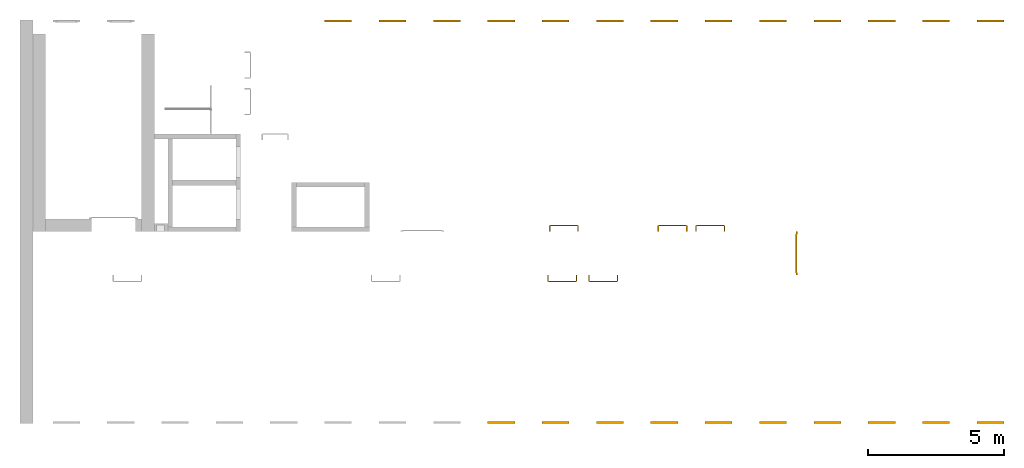
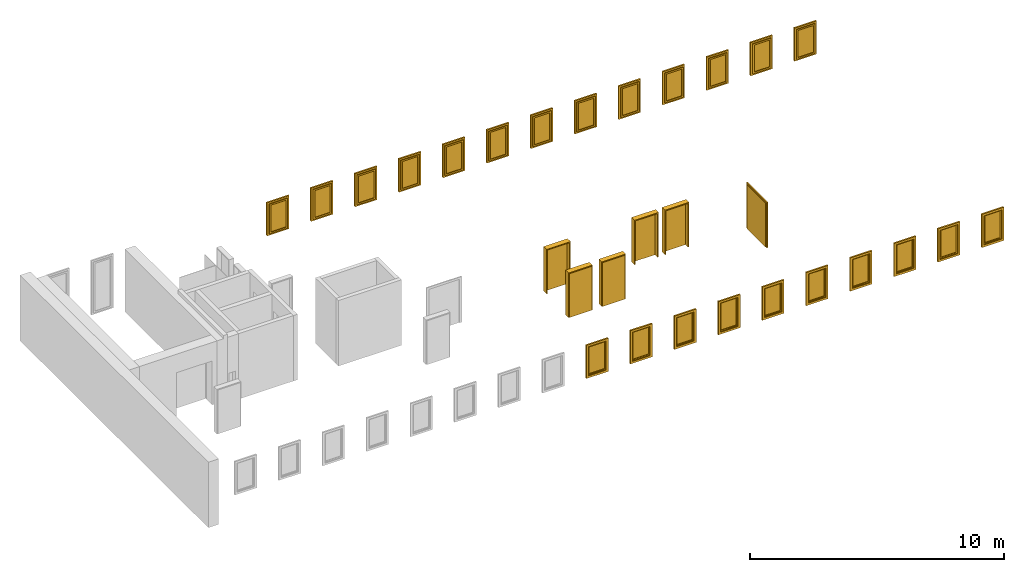
# One storey, part 3 of 3: 23 windows, 6 doors.
"""IFC4 building model written with IfcOpenShell, lengths in metres."""

from ifc_helpers import new_model, entity, si_unit, converted_unit, derived_unit, direction, frame, origin_with_axes, place, context, subcontext, project, spatial, polygons, source, transform, mapped, type_object, element, save


model = new_model("IFC4")

# Units and contexts
model_context = context("Model", 3, precision=1e-05, world=origin_with_axes(), true_north=direction((0.0, 1.0)))
body_context = subcontext(model_context, "Body", "Model", "MODEL_VIEW")
ifc_project = project(units=[si_unit("LENGTHUNIT", "METRE"), si_unit("AREAUNIT", "SQUARE_METRE"), si_unit("VOLUMEUNIT", "CUBIC_METRE"), converted_unit("PLANEANGLEUNIT", "DEGREE", entity("IfcPlaneAngleMeasure", 0.0174532925199433), si_unit("PLANEANGLEUNIT", "RADIAN"), dimensions=[0, 0, 0, 0, 0, 0, 0]), converted_unit("TIMEUNIT", "Year", entity("IfcTimeMeasure", 31557600.0), si_unit("TIMEUNIT", "SECOND"), dimensions=[0, 0, 1, 0, 0, 0, 0]), si_unit("MASSUNIT", "GRAM", prefix="KILO"), si_unit("THERMODYNAMICTEMPERATUREUNIT", "DEGREE_CELSIUS"), si_unit("LUMINOUSINTENSITYUNIT", "LUMEN"), si_unit("ENERGYUNIT", "JOULE", prefix="MEGA"), derived_unit("THERMALCONDUCTANCEUNIT", [(si_unit("POWERUNIT", "WATT"), 1), (si_unit("LENGTHUNIT", "METRE"), -1), (si_unit("THERMODYNAMICTEMPERATUREUNIT", "KELVIN"), -1)]), derived_unit("SPECIFICHEATCAPACITYUNIT", [(si_unit("ENERGYUNIT", "JOULE"), 1), (si_unit("MASSUNIT", "GRAM", prefix="KILO"), -1), (si_unit("THERMODYNAMICTEMPERATUREUNIT", "KELVIN"), -1)]), derived_unit("MASSDENSITYUNIT", [(si_unit("MASSUNIT", "GRAM", prefix="KILO"), 1), (si_unit("VOLUMEUNIT", "CUBIC_METRE"), -1)])], contexts=[model_context])

# Site, building, storey
site_placement = place(None, origin_with_axes())
site = spatial("IfcSite", under=ifc_project, at=site_placement, CompositionType="ELEMENT")
building_placement = place(None, origin_with_axes())
building = spatial("IfcBuilding", under=site, at=building_placement, CompositionType="ELEMENT")
storey_placement = place(None, frame((0.0, 0.0, 10.5), z_axis=(0.0, 0.0, 1.0), x_axis=(1.0, 0.0, 0.0)))
storey = spatial("IfcBuildingStorey", under=building, at=storey_placement, Name="3 OG", CompositionType="ELEMENT", Elevation=10.5)

# Windows
window_type = type_object("IfcWindowType", Name="1-27", PartitioningType="SINGLE_PANEL", PredefinedType="WINDOW")
shared_shape_1 = source(origin_with_axes(), body_context, "Body", "Tessellation", [
    polygons([(-0.5, -0.07, 0.0), (-0.5, 0.0, 0.0), (-0.4, 0.0, 0.1), (-0.4, -0.07, 0.1), (-0.5, -0.07, 1.6), (-0.5, 0.0, 1.6), (-0.4, 0.0, 1.5), (-0.4, -0.07, 1.5)], [[[1, 2, 3, 4]], [[5, 6, 2, 1]], [[2, 6, 7, 3]], [[4, 3, 7, 8]], [[1, 4, 8, 5]], [[8, 7, 6, 5]]], closed=True),
    polygons([(0.5, -0.07, 0.0), (0.5, 0.0, 0.0), (0.5, 0.0, 1.6), (0.5, -0.07, 1.6), (0.4, -0.07, 0.1), (0.4, 0.0, 0.1), (0.4, 0.0, 1.5), (0.4, -0.07, 1.5)], [[[1, 2, 3, 4]], [[5, 6, 2, 1]], [[2, 6, 7, 3]], [[4, 3, 7, 8]], [[1, 4, 8, 5]], [[8, 7, 6, 5]]], closed=True),
    polygons([(-0.5, -0.07, 0.0), (-0.5, 0.0, 0.0), (0.5, 0.0, 0.0), (0.5, -0.07, 0.0), (-0.4, -0.07, 0.1), (-0.4, 0.0, 0.1), (0.0, 0.0, 0.1), (0.4, 0.0, 0.1), (0.4, -0.07, 0.1), (0.0, -0.07, 0.1)], [[[1, 2, 3, 4]], [[5, 6, 2, 1]], [[2, 6, 7, 8, 3]], [[4, 3, 8, 9]], [[1, 4, 9, 10, 5]], [[10, 7, 6, 5]], [[9, 8, 7, 10]]], closed=True),
    polygons([(-0.5, -0.07, 1.6), (-0.5, 0.0, 1.6), (-0.4, 0.0, 1.5), (-0.4, -0.07, 1.5), (0.5, -0.07, 1.6), (0.5, 0.0, 1.6), (0.4, 0.0, 1.5), (0.0, 0.0, 1.5), (0.0, -0.07, 1.5), (0.4, -0.07, 1.5)], [[[1, 2, 3, 4]], [[5, 6, 2, 1]], [[2, 6, 7, 8, 3]], [[4, 3, 8, 9]], [[1, 4, 9, 10, 5]], [[10, 7, 6, 5]], [[9, 8, 7, 10]]], closed=True),
    polygons([(-0.42, 0.0, 0.08), (-0.42, 0.03, 0.08), (-0.35, 0.03, 0.15), (-0.35, 0.0, 0.15), (-0.42, 0.0, 1.52), (-0.42, 0.03, 1.52), (-0.35, 0.03, 1.45), (-0.35, 0.0, 1.45)], [[[1, 2, 3, 4]], [[5, 6, 2, 1]], [[2, 6, 7, 3]], [[4, 3, 7, 8]], [[1, 4, 8, 5]], [[8, 7, 6, 5]]], closed=True),
    polygons([(0.42, 0.0, 0.08), (0.35, 0.0, 0.15), (0.35, 0.03, 0.15), (0.42, 0.03, 0.08), (0.42, 0.0, 1.52), (0.35, 0.0, 1.45), (0.35, 0.03, 1.45), (0.42, 0.03, 1.52)], [[[1, 2, 3, 4]], [[1, 5, 6, 2]], [[2, 6, 7, 3]], [[4, 3, 7, 8]], [[5, 1, 4, 8]], [[6, 5, 8, 7]]], closed=True),
    polygons([(-0.42, 0.0, 0.08), (-0.42, 0.03, 0.08), (0.42, 0.03, 0.08), (0.42, 0.0, 0.08), (-0.35, 0.0, 0.15), (-0.35, 0.03, 0.15), (0.35, 0.03, 0.15), (0.35, 0.0, 0.15)], [[[1, 2, 3, 4]], [[5, 6, 2, 1]], [[2, 6, 7, 3]], [[4, 3, 7, 8]], [[1, 4, 8, 5]], [[8, 7, 6, 5]]], closed=True),
    polygons([(-0.42, 0.0, 1.52), (0.42, 0.0, 1.52), (0.42, 0.03, 1.52), (-0.42, 0.03, 1.52), (-0.35, 0.0, 1.45), (0.35, 0.0, 1.45), (0.35, 0.03, 1.45), (-0.35, 0.03, 1.45)], [[[1, 2, 3, 4]], [[1, 5, 6, 2]], [[2, 6, 7, 3]], [[4, 3, 7, 8]], [[5, 1, 4, 8]], [[6, 5, 8, 7]]], closed=True),
    polygons([(-0.4, -0.03, 0.1), (-0.4, 0.0, 0.1), (-0.35, 0.0, 0.15), (-0.35, -0.03, 0.15), (-0.4, -0.03, 1.5), (-0.4, 0.0, 1.5), (-0.35, 0.0, 1.45), (-0.35, -0.03, 1.45)], [[[1, 2, 3, 4]], [[5, 6, 2, 1]], [[2, 6, 7, 3]], [[4, 3, 7, 8]], [[1, 4, 8, 5]], [[8, 7, 6, 5]]], closed=True),
    polygons([(0.4, -0.03, 0.1), (0.35, -0.03, 0.15), (0.35, 0.0, 0.15), (0.4, 0.0, 0.1), (0.4, -0.03, 1.5), (0.35, -0.03, 1.45), (0.35, 0.0, 1.45), (0.4, 0.0, 1.5)], [[[1, 2, 3, 4]], [[1, 5, 6, 2]], [[2, 6, 7, 3]], [[4, 3, 7, 8]], [[5, 1, 4, 8]], [[6, 5, 8, 7]]], closed=True),
    polygons([(-0.4, -0.03, 0.1), (-0.4, 0.0, 0.1), (0.4, 0.0, 0.1), (0.4, -0.03, 0.1), (-0.35, -0.03, 0.15), (-0.35, 0.0, 0.15), (0.35, 0.0, 0.15), (0.35, -0.03, 0.15)], [[[1, 2, 3, 4]], [[5, 6, 2, 1]], [[2, 6, 7, 3]], [[4, 3, 7, 8]], [[1, 4, 8, 5]], [[8, 7, 6, 5]]], closed=True),
    polygons([(-0.4, -0.03, 1.5), (0.4, -0.03, 1.5), (0.4, 0.0, 1.5), (-0.4, 0.0, 1.5), (-0.35, -0.03, 1.45), (0.35, -0.03, 1.45), (0.35, 0.0, 1.45), (-0.35, 0.0, 1.45)], [[[1, 2, 3, 4]], [[1, 5, 6, 2]], [[2, 6, 7, 3]], [[4, 3, 7, 8]], [[5, 1, 4, 8]], [[6, 5, 8, 7]]], closed=True),
    polygons([(-0.35, -0.00500000000000001, 0.15), (-0.35, 0.00499999999999999, 0.15), (0.35, 0.00499999999999999, 0.15), (0.35, -0.00500000000000001, 0.15), (-0.35, -0.00500000000000001, 1.45), (-0.35, 0.00499999999999999, 1.45), (0.35, 0.00499999999999999, 1.45), (0.35, -0.00500000000000001, 1.45)], [[[1, 2, 3, 4]], [[5, 6, 2, 1]], [[2, 6, 7, 3]], [[4, 3, 7, 8]], [[1, 4, 8, 5]], [[8, 7, 6, 5]]], closed=True),
])
window_1_placement = place(None, frame((58.723, 0.0, 11.5), z_axis=(0.0, 0.0, 1.0), x_axis=(1.0, 0.0, 0.0)))
element("IfcWindow", 1, at=window_1_placement, inside=storey, type_object=window_type, Name="Fenster-001", OverallHeight=1.6, OverallWidth=1.0, context=body_context, shape_type="MappedRepresentation", body=[
    mapped(shared_shape_1, transform((0.5, 0.0700000000000001, 0.0))),
])
window_2_placement = place(None, frame((46.723, 0.0, 11.5), z_axis=(0.0, 0.0, 1.0), x_axis=(1.0, 0.0, 0.0)))
element("IfcWindow", 2, at=window_2_placement, inside=storey, type_object=window_type, Name="Fenster-001", OverallHeight=1.6, OverallWidth=1.0, context=body_context, shape_type="MappedRepresentation", body=[
    mapped(shared_shape_1, transform((0.5, 0.0700000000000016, 0.0))),
])
window_3_placement = place(None, frame((56.7209324704699, 0.0, 11.5), z_axis=(0.0, 0.0, 1.0), x_axis=(1.0, 0.0, 0.0)))
element("IfcWindow", 3, at=window_3_placement, inside=storey, type_object=window_type, Name="Fenster-001", OverallHeight=1.6, OverallWidth=1.0, context=body_context, shape_type="MappedRepresentation", body=[
    mapped(shared_shape_1, transform((0.5, 0.0700000000000004, 0.0))),
])
window_4_placement = place(None, frame((55.723, 14.8459998909351, 11.5), z_axis=(0.0, 0.0, 1.0), x_axis=(-1.0, 0.0, 0.0)))
element("IfcWindow", 4, at=window_4_placement, inside=storey, type_object=window_type, Name="Fenster-002", OverallHeight=1.6, OverallWidth=1.0, context=body_context, shape_type="MappedRepresentation", body=[
    mapped(shared_shape_1, transform((0.5, 0.0700000000000003, 0.0))),
])
window_5_placement = place(None, frame((44.723, 0.0, 11.5), z_axis=(0.0, 0.0, 1.0), x_axis=(1.0, 0.0, 0.0)))
element("IfcWindow", 5, at=window_5_placement, inside=storey, type_object=window_type, Name="Fenster-001", OverallHeight=1.6, OverallWidth=1.0, context=body_context, shape_type="MappedRepresentation", body=[
    mapped(shared_shape_1, transform((0.5, 0.0700000000000018, 0.0))),
])
window_6_placement = place(None, frame((50.723, 0.0, 11.5), z_axis=(0.0, 0.0, 1.0), x_axis=(1.0, 0.0, 0.0)))
element("IfcWindow", 6, at=window_6_placement, inside=storey, type_object=window_type, Name="Fenster-001", OverallHeight=1.6, OverallWidth=1.0, context=body_context, shape_type="MappedRepresentation", body=[
    mapped(shared_shape_1, transform((0.5, 0.0700000000000011, 0.0))),
])
window_7_placement = place(None, frame((54.7256338620337, 0.0, 11.5), z_axis=(0.0, 0.0, 1.0), x_axis=(1.0, 0.0, 0.0)))
element("IfcWindow", 7, at=window_7_placement, inside=storey, type_object=window_type, Name="Fenster-001", OverallHeight=1.6, OverallWidth=1.0, context=body_context, shape_type="MappedRepresentation", body=[
    mapped(shared_shape_1, transform((0.5, 0.0700000000000006, 0.0))),
])
window_8_placement = place(None, frame((48.723, 0.0, 11.5), z_axis=(0.0, 0.0, 1.0), x_axis=(1.0, 0.0, 0.0)))
element("IfcWindow", 8, at=window_8_placement, inside=storey, type_object=window_type, Name="Fenster-001", OverallHeight=1.6, OverallWidth=1.0, context=body_context, shape_type="MappedRepresentation", body=[
    mapped(shared_shape_1, transform((0.5, 0.0700000000000013, 0.0))),
])
window_9_placement = place(None, frame((52.723, 0.0, 11.5), z_axis=(0.0, 0.0, 1.0), x_axis=(1.0, 0.0, 0.0)))
element("IfcWindow", 9, at=window_9_placement, inside=storey, type_object=window_type, Name="Fenster-001", OverallHeight=1.6, OverallWidth=1.0, context=body_context, shape_type="MappedRepresentation", body=[
    mapped(shared_shape_1, transform((0.5, 0.0700000000000008, 0.0))),
])
window_10_placement = place(None, frame((42.723, 0.0, 11.5), z_axis=(0.0, 0.0, 1.0), x_axis=(1.0, 0.0, 0.0)))
element("IfcWindow", 10, at=window_10_placement, inside=storey, type_object=window_type, Name="Fenster-001", OverallHeight=1.6, OverallWidth=1.0, context=body_context, shape_type="MappedRepresentation", body=[
    mapped(shared_shape_1, transform((0.5, 0.0700000000000021, 0.0))),
])
window_11_placement = place(None, frame((59.723, 14.8459998909351, 11.5), z_axis=(0.0, 0.0, 1.0), x_axis=(-1.0, 0.0, 0.0)))
element("IfcWindow", 11, at=window_11_placement, inside=storey, type_object=window_type, Name="Fenster-004", OverallHeight=1.6, OverallWidth=1.0, context=body_context, shape_type="MappedRepresentation", body=[
    mapped(shared_shape_1, transform((0.5, 0.0700000000000003, 0.0))),
])
window_12_placement = place(None, frame((40.723, 0.0, 11.5), z_axis=(0.0, 0.0, 1.0), x_axis=(1.0, 0.0, 0.0)))
element("IfcWindow", 12, at=window_12_placement, inside=storey, type_object=window_type, Name="Fenster-001", OverallHeight=1.6, OverallWidth=1.0, context=body_context, shape_type="MappedRepresentation", body=[
    mapped(shared_shape_1, transform((0.5, 0.0700000000000023, 0.0))),
])
window_13_placement = place(None, frame((57.723, 14.8459998909351, 11.5), z_axis=(0.0, 0.0, 1.0), x_axis=(-1.0, 0.0, 0.0)))
element("IfcWindow", 13, at=window_13_placement, inside=storey, type_object=window_type, Name="Fenster-003", OverallHeight=1.6, OverallWidth=1.0, context=body_context, shape_type="MappedRepresentation", body=[
    mapped(shared_shape_1, transform((0.5, 0.0700000000000003, 0.0))),
])
shared_shape_2 = source(origin_with_axes(), body_context, "Body", "Tessellation", [
    polygons([(0.5, -0.07, 0.0), (0.4, -0.07, 0.1), (0.4, 0.0, 0.1), (0.5, 0.0, 0.0), (0.5, -0.07, 1.6), (0.4, -0.07, 1.5), (0.4, 0.0, 1.5), (0.5, 0.0, 1.6)], [[[1, 2, 3, 4]], [[1, 5, 6, 2]], [[2, 6, 7, 3]], [[4, 3, 7, 8]], [[5, 1, 4, 8]], [[6, 5, 8, 7]]], closed=True),
    polygons([(-0.5, -0.07, 0.0), (-0.5, -0.07, 1.6), (-0.5, 0.0, 1.6), (-0.5, 0.0, 0.0), (-0.4, -0.07, 0.1), (-0.4, -0.07, 1.5), (-0.4, 0.0, 1.5), (-0.4, 0.0, 0.1)], [[[1, 2, 3, 4]], [[1, 5, 6, 2]], [[2, 6, 7, 3]], [[4, 3, 7, 8]], [[5, 1, 4, 8]], [[6, 5, 8, 7]]], closed=True),
    polygons([(0.5, -0.07, 0.0), (-0.5, -0.07, 0.0), (-0.5, 0.0, 0.0), (0.5, 0.0, 0.0), (0.4, -0.07, 0.1), (0.0, -0.07, 0.1), (-0.4, -0.07, 0.1), (-0.4, 0.0, 0.1), (0.0, 0.0, 0.1), (0.4, 0.0, 0.1)], [[[1, 2, 3, 4]], [[1, 5, 6, 7, 2]], [[2, 7, 8, 3]], [[4, 3, 8, 9, 10]], [[5, 1, 4, 10]], [[6, 5, 10, 9]], [[7, 6, 9, 8]]], closed=True),
    polygons([(0.5, -0.07, 1.6), (0.4, -0.07, 1.5), (0.4, 0.0, 1.5), (0.5, 0.0, 1.6), (-0.5, -0.07, 1.6), (-0.4, -0.07, 1.5), (0.0, -0.07, 1.5), (0.0, 0.0, 1.5), (-0.4, 0.0, 1.5), (-0.5, 0.0, 1.6)], [[[1, 2, 3, 4]], [[1, 5, 6, 7, 2]], [[2, 7, 8, 3]], [[4, 3, 8, 9, 10]], [[5, 1, 4, 10]], [[6, 5, 10, 9]], [[7, 6, 9, 8]]], closed=True),
    polygons([(0.42, 0.0, 0.08), (0.35, 0.0, 0.15), (0.35, 0.03, 0.15), (0.42, 0.03, 0.08), (0.42, 0.0, 1.52), (0.35, 0.0, 1.45), (0.35, 0.03, 1.45), (0.42, 0.03, 1.52)], [[[1, 2, 3, 4]], [[1, 5, 6, 2]], [[2, 6, 7, 3]], [[4, 3, 7, 8]], [[5, 1, 4, 8]], [[6, 5, 8, 7]]], closed=True),
    polygons([(-0.42, 0.0, 0.08), (-0.42, 0.03, 0.08), (-0.35, 0.03, 0.15), (-0.35, 0.0, 0.15), (-0.42, 0.0, 1.52), (-0.42, 0.03, 1.52), (-0.35, 0.03, 1.45), (-0.35, 0.0, 1.45)], [[[1, 2, 3, 4]], [[5, 6, 2, 1]], [[2, 6, 7, 3]], [[4, 3, 7, 8]], [[1, 4, 8, 5]], [[8, 7, 6, 5]]], closed=True),
    polygons([(0.42, 0.0, 0.08), (-0.42, 0.0, 0.08), (-0.42, 0.03, 0.08), (0.42, 0.03, 0.08), (0.35, 0.0, 0.15), (-0.35, 0.0, 0.15), (-0.35, 0.03, 0.15), (0.35, 0.03, 0.15)], [[[1, 2, 3, 4]], [[1, 5, 6, 2]], [[2, 6, 7, 3]], [[4, 3, 7, 8]], [[5, 1, 4, 8]], [[6, 5, 8, 7]]], closed=True),
    polygons([(0.42, 0.0, 1.52), (0.42, 0.03, 1.52), (-0.42, 0.03, 1.52), (-0.42, 0.0, 1.52), (0.35, 0.0, 1.45), (0.35, 0.03, 1.45), (-0.35, 0.03, 1.45), (-0.35, 0.0, 1.45)], [[[1, 2, 3, 4]], [[5, 6, 2, 1]], [[2, 6, 7, 3]], [[4, 3, 7, 8]], [[1, 4, 8, 5]], [[8, 7, 6, 5]]], closed=True),
    polygons([(0.4, -0.03, 0.1), (0.35, -0.03, 0.15), (0.35, 0.0, 0.15), (0.4, 0.0, 0.1), (0.4, -0.03, 1.5), (0.35, -0.03, 1.45), (0.35, 0.0, 1.45), (0.4, 0.0, 1.5)], [[[1, 2, 3, 4]], [[1, 5, 6, 2]], [[2, 6, 7, 3]], [[4, 3, 7, 8]], [[5, 1, 4, 8]], [[6, 5, 8, 7]]], closed=True),
    polygons([(-0.4, -0.03, 0.1), (-0.4, 0.0, 0.1), (-0.35, 0.0, 0.15), (-0.35, -0.03, 0.15), (-0.4, -0.03, 1.5), (-0.4, 0.0, 1.5), (-0.35, 0.0, 1.45), (-0.35, -0.03, 1.45)], [[[1, 2, 3, 4]], [[5, 6, 2, 1]], [[2, 6, 7, 3]], [[4, 3, 7, 8]], [[1, 4, 8, 5]], [[8, 7, 6, 5]]], closed=True),
    polygons([(0.4, -0.03, 0.1), (-0.4, -0.03, 0.1), (-0.4, 0.0, 0.1), (0.4, 0.0, 0.1), (0.35, -0.03, 0.15), (-0.35, -0.03, 0.15), (-0.35, 0.0, 0.15), (0.35, 0.0, 0.15)], [[[1, 2, 3, 4]], [[1, 5, 6, 2]], [[2, 6, 7, 3]], [[4, 3, 7, 8]], [[5, 1, 4, 8]], [[6, 5, 8, 7]]], closed=True),
    polygons([(0.4, -0.03, 1.5), (0.4, 0.0, 1.5), (-0.4, 0.0, 1.5), (-0.4, -0.03, 1.5), (0.35, -0.03, 1.45), (0.35, 0.0, 1.45), (-0.35, 0.0, 1.45), (-0.35, -0.03, 1.45)], [[[1, 2, 3, 4]], [[5, 6, 2, 1]], [[2, 6, 7, 3]], [[4, 3, 7, 8]], [[1, 4, 8, 5]], [[8, 7, 6, 5]]], closed=True),
    polygons([(0.35, -0.00500000000000001, 0.15), (-0.35, -0.00500000000000001, 0.15), (-0.35, 0.00499999999999999, 0.15), (0.35, 0.00499999999999999, 0.15), (0.35, -0.00500000000000001, 1.45), (-0.35, -0.00500000000000001, 1.45), (-0.35, 0.00499999999999999, 1.45), (0.35, 0.00499999999999999, 1.45)], [[[1, 2, 3, 4]], [[1, 5, 6, 2]], [[2, 6, 7, 3]], [[4, 3, 7, 8]], [[5, 1, 4, 8]], [[6, 5, 8, 7]]], closed=True),
])
window_14_placement = place(None, frame((39.723, 14.8459998909351, 11.5), z_axis=(0.0, 0.0, 1.0), x_axis=(-1.0, 0.0, 0.0)))
element("IfcWindow", 14, at=window_14_placement, inside=storey, type_object=window_type, Name="Fenster-001", OverallHeight=1.6, OverallWidth=1.0, context=body_context, shape_type="MappedRepresentation", body=[
    mapped(shared_shape_2, transform((0.5, 0.0699999999999985, 0.0))),
])
window_15_placement = place(None, frame((35.723, 14.8459998909351, 11.5), z_axis=(0.0, 0.0, 1.0), x_axis=(-1.0, 0.0, 0.0)))
element("IfcWindow", 15, at=window_15_placement, inside=storey, type_object=window_type, Name="Fenster-001", OverallHeight=1.6, OverallWidth=1.0, context=body_context, shape_type="MappedRepresentation", body=[
    mapped(shared_shape_2, transform((0.5, 0.0699999999999967, 0.0))),
])
for number, where, z_axis, x_axis, name in (
    (16, (43.723, 14.8459998909351, 11.5), (0.0, 0.0, 1.0), (-1.0, 0.0, 0.0), "Fenster-001"),
    (17, (45.723, 14.8459998909351, 11.5), (0.0, 0.0, 1.0), (-1.0, 0.0, 0.0), "Fenster-001"),
):
    element("IfcWindow", number, at=place(None, frame(where, z_axis=z_axis, x_axis=x_axis)), inside=storey, type_object=window_type, Name=name, OverallHeight=1.6, OverallWidth=1.0, context=body_context, shape_type="MappedRepresentation", body=[
        mapped(shared_shape_2, transform((0.5, 0.0699999999999985, 0.0))),
    ])
window_16_placement = place(None, frame((53.723, 14.8459998909351, 11.5), z_axis=(0.0, 0.0, 1.0), x_axis=(-1.0, 0.0, 0.0)))
element("IfcWindow", 18, at=window_16_placement, inside=storey, type_object=window_type, Name="Fenster-001", OverallHeight=1.6, OverallWidth=1.0, context=body_context, shape_type="MappedRepresentation", body=[
    mapped(shared_shape_2, transform((0.5, 0.0700000000000003, 0.0))),
])
for number, where, z_axis, x_axis, name in (
    (19, (49.723, 14.8459998909351, 11.5), (0.0, 0.0, 1.0), (-1.0, 0.0, 0.0), "Fenster-001"),
    (20, (47.723, 14.8459998909351, 11.5), (0.0, 0.0, 1.0), (-1.0, 0.0, 0.0), "Fenster-001"),
):
    element("IfcWindow", number, at=place(None, frame(where, z_axis=z_axis, x_axis=x_axis)), inside=storey, type_object=window_type, Name=name, OverallHeight=1.6, OverallWidth=1.0, context=body_context, shape_type="MappedRepresentation", body=[
        mapped(shared_shape_2, transform((0.5, 0.0699999999999985, 0.0))),
    ])
window_17_placement = place(None, frame((37.723, 14.8459998909351, 11.5), z_axis=(0.0, 0.0, 1.0), x_axis=(-1.0, 0.0, 0.0)))
element("IfcWindow", 21, at=window_17_placement, inside=storey, type_object=window_type, Name="Fenster-001", OverallHeight=1.6, OverallWidth=1.0, context=body_context, shape_type="MappedRepresentation", body=[
    mapped(shared_shape_2, transform((0.5, 0.0699999999999967, 0.0))),
])
for number, where, z_axis, x_axis, name in (
    (22, (51.723, 14.8459998909351, 11.5), (0.0, 0.0, 1.0), (-1.0, 0.0, 0.0), "Fenster-001"),
    (23, (41.723, 14.8459998909351, 11.5), (0.0, 0.0, 1.0), (-1.0, 0.0, 0.0), "Fenster-001"),
):
    element("IfcWindow", number, at=place(None, frame(where, z_axis=z_axis, x_axis=x_axis)), inside=storey, type_object=window_type, Name=name, OverallHeight=1.6, OverallWidth=1.0, context=body_context, shape_type="MappedRepresentation", body=[
        mapped(shared_shape_2, transform((0.5, 0.0699999999999985, 0.0))),
    ])

# Doors
door_type_1 = type_object("IfcDoorType", Name="27", OperationType="SINGLE_SWING_RIGHT", PredefinedType="DOOR")
shared_shape_3 = source(origin_with_axes(), body_context, "Body", "Tessellation", [
    polygons([(0.545, -0.2325, 0.0), (0.545, -0.025, 0.0), (0.545, -0.025, 2.145), (0.545, -0.2325, 2.145), (0.5, -0.2325, 0.0), (0.5, -0.025, 0.0), (0.5, -0.025, 2.1), (0.0551, -0.025, 2.1), (0.0001, -0.025, 2.1), (-0.5, -0.025, 2.1), (-0.5, -0.025, 0.0), (-0.545, -0.025, 0.0), (-0.545, -0.025, 2.145), (-0.545, -0.2325, 2.145), (-0.545, -0.2325, 0.0), (-0.5, -0.2325, 0.0), (-0.5, -0.2325, 2.1), (0.0001, -0.2325, 2.1), (0.0551, -0.2325, 2.1), (0.5, -0.2325, 2.1)], [[[1, 2, 3, 4]], [[5, 6, 2, 1]], [[2, 6, 7, 8, 9, 10, 11, 12, 13, 3]], [[4, 3, 13, 14]], [[1, 4, 14, 15, 16, 17, 18, 19, 20, 5]], [[20, 7, 6, 5]], [[19, 8, 7, 20]], [[18, 9, 8, 19]], [[17, 10, 9, 18]], [[16, 11, 10, 17]], [[15, 12, 11, 16]], [[14, 13, 12, 15]]], closed=True),
    polygons([(0.545, -0.025, 0.0), (0.545, 0.0, 0.0), (0.545, 0.0, 2.145), (0.545, -0.025, 2.145), (0.51, -0.025, 0.0), (0.51, 0.0, 0.0), (0.51, 0.0, 2.11), (0.0451, 0.0, 2.11), (0.0101, 0.0, 2.11), (-0.51, 0.0, 2.11), (-0.51, 0.0, 0.0), (-0.545, 0.0, 0.0), (-0.545, 0.0, 2.145), (-0.545, -0.025, 2.145), (-0.545, -0.025, 0.0), (-0.51, -0.025, 0.0), (-0.51, -0.025, 2.11), (0.0101, -0.025, 2.11), (0.0451, -0.025, 2.11), (0.51, -0.025, 2.11)], [[[1, 2, 3, 4]], [[5, 6, 2, 1]], [[2, 6, 7, 8, 9, 10, 11, 12, 13, 3]], [[4, 3, 13, 14]], [[1, 4, 14, 15, 16, 17, 18, 19, 20, 5]], [[20, 7, 6, 5]], [[19, 8, 7, 20]], [[18, 9, 8, 19]], [[17, 10, 9, 18]], [[16, 11, 10, 17]], [[15, 12, 11, 16]], [[14, 13, 12, 15]]], closed=True),
    polygons([(0.51, 0.015, 0.0), (-0.51, 0.015, 0.0), (-0.51, 0.015, 2.11), (0.51, 0.015, 2.11), (0.51, -0.025, 0.0), (-0.51, -0.025, 0.0), (-0.51, -0.025, 2.11), (0.51, -0.025, 2.11)], [[[1, 2, 3, 4]], [[2, 1, 5, 6]], [[3, 2, 6, 7]], [[4, 3, 7, 8]], [[1, 4, 8, 5]], [[6, 5, 8, 7]]], closed=True),
])
door_1_placement = place(None, frame((47.028, 7.05499994546756, 10.5), z_axis=(0.0, 0.0, 1.0), x_axis=(1.0, 0.0, 0.0)))
element("IfcDoor", 24, at=door_1_placement, inside=storey, type_object=door_type_1, OverallHeight=2.145, OverallWidth=1.09, context=body_context, shape_type="MappedRepresentation", body=[
    mapped(shared_shape_3, transform((0.5, 0.232500000000001, 0.0))),
])
door_2_placement = place(None, frame((43.028, 7.05499994546756, 10.5), z_axis=(0.0, 0.0, 1.0), x_axis=(1.0, 0.0, 0.0)))
element("IfcDoor", 25, at=door_2_placement, inside=storey, type_object=door_type_1, OverallHeight=2.145, OverallWidth=1.09, context=body_context, shape_type="MappedRepresentation", body=[
    mapped(shared_shape_3, transform((0.5, 0.232500000000002, 0.0))),
])
door_3_placement = place(None, frame((45.477, 5.45499994546755, 10.5), z_axis=(0.0, 0.0, 1.0), x_axis=(-1.0, 0.0, 0.0)))
element("IfcDoor", 26, at=door_3_placement, inside=storey, type_object=door_type_1, OverallHeight=2.145, OverallWidth=1.09, context=body_context, shape_type="MappedRepresentation", body=[
    mapped(shared_shape_3, transform((0.5, 0.2325, 0.0))),
])
door_type_2 = type_object("IfcDoorType", Name="27", OperationType="SINGLE_SWING_LEFT", PredefinedType="DOOR")
shared_shape_4 = source(origin_with_axes(), body_context, "Body", "Tessellation", [
    polygons([(-0.545, -0.2325, 0.0), (-0.545, -0.2325, 2.145), (-0.545, -0.025, 2.145), (-0.545, -0.025, 0.0), (-0.5, -0.2325, 0.0), (-0.5, -0.2325, 2.1), (-0.0551, -0.2325, 2.1), (-0.0001, -0.2325, 2.1), (0.5, -0.2325, 2.1), (0.5, -0.2325, 0.0), (0.545, -0.2325, 0.0), (0.545, -0.2325, 2.145), (0.545, -0.025, 2.145), (0.545, -0.025, 0.0), (0.5, -0.025, 0.0), (0.5, -0.025, 2.1), (-0.0001, -0.025, 2.1), (-0.0551, -0.025, 2.1), (-0.5, -0.025, 2.1), (-0.5, -0.025, 0.0)], [[[1, 2, 3, 4]], [[1, 5, 6, 7, 8, 9, 10, 11, 12, 2]], [[2, 12, 13, 3]], [[4, 3, 13, 14, 15, 16, 17, 18, 19, 20]], [[5, 1, 4, 20]], [[6, 5, 20, 19]], [[7, 6, 19, 18]], [[8, 7, 18, 17]], [[9, 8, 17, 16]], [[10, 9, 16, 15]], [[11, 10, 15, 14]], [[12, 11, 14, 13]]], closed=True),
    polygons([(-0.545, -0.025, 0.0), (-0.545, -0.025, 2.145), (-0.545, 0.0, 2.145), (-0.545, 0.0, 0.0), (-0.51, -0.025, 0.0), (-0.51, -0.025, 2.11), (-0.0451, -0.025, 2.11), (-0.0101, -0.025, 2.11), (0.51, -0.025, 2.11), (0.51, -0.025, 0.0), (0.545, -0.025, 0.0), (0.545, -0.025, 2.145), (0.545, 0.0, 2.145), (0.545, 0.0, 0.0), (0.51, 0.0, 0.0), (0.51, 0.0, 2.11), (-0.0101, 0.0, 2.11), (-0.0451, 0.0, 2.11), (-0.51, 0.0, 2.11), (-0.51, 0.0, 0.0)], [[[1, 2, 3, 4]], [[1, 5, 6, 7, 8, 9, 10, 11, 12, 2]], [[2, 12, 13, 3]], [[4, 3, 13, 14, 15, 16, 17, 18, 19, 20]], [[5, 1, 4, 20]], [[6, 5, 20, 19]], [[7, 6, 19, 18]], [[8, 7, 18, 17]], [[9, 8, 17, 16]], [[10, 9, 16, 15]], [[11, 10, 15, 14]], [[12, 11, 14, 13]]], closed=True),
    polygons([(-0.51, 0.015, 0.0), (-0.51, 0.015, 2.11), (0.51, 0.015, 2.11), (0.51, 0.015, 0.0), (-0.51, -0.025, 0.0), (-0.51, -0.025, 2.11), (0.51, -0.025, 2.11), (0.51, -0.025, 0.0)], [[[1, 2, 3, 4]], [[1, 5, 6, 2]], [[2, 6, 7, 3]], [[3, 7, 8, 4]], [[4, 8, 5, 1]], [[8, 7, 6, 5]]], closed=True),
])
door_4_placement = place(None, frame((43.969, 5.45499994546755, 10.5), z_axis=(0.0, 0.0, 1.0), x_axis=(-1.0, 0.0, 0.0)))
element("IfcDoor", 27, at=door_4_placement, inside=storey, type_object=door_type_2, OverallHeight=2.145, OverallWidth=1.09, context=body_context, shape_type="MappedRepresentation", body=[
    mapped(shared_shape_4, transform((0.5, 0.2325, 0.0))),
])
door_5_placement = place(None, frame((48.418, 7.05499994546756, 10.5), z_axis=(0.0, 0.0, 1.0), x_axis=(1.0, 0.0, 0.0)))
element("IfcDoor", 28, at=door_5_placement, inside=storey, type_object=door_type_2, OverallHeight=2.145, OverallWidth=1.09, context=body_context, shape_type="MappedRepresentation", body=[
    mapped(shared_shape_4, transform((0.5, 0.232500000000002, 0.0))),
])
door_type_3 = type_object("IfcDoorType", Name="2-Fl 27", OperationType="DOUBLE_DOOR_SINGLE_SWING", PredefinedType="DOOR")
shared_shape_5 = source(origin_with_axes(), body_context, "Body", "Tessellation", [
    polygons([(0.8, -0.05, 0.0), (0.8, -0.02, 0.0), (0.8, -0.02, 2.2), (0.8, -0.05, 2.2), (0.7, -0.05, 0.0), (0.7, -0.02, 0.0), (0.7, -0.02, 2.1), (0.1251, -0.02, 2.1), (0.0001, -0.02, 2.1), (-0.7, -0.02, 2.1), (-0.7, -0.02, 0.0), (-0.8, -0.02, 0.0), (-0.8, -0.02, 2.2), (-0.8, -0.05, 2.2), (-0.8, -0.05, 0.0), (-0.7, -0.05, 0.0), (-0.7, -0.05, 2.1), (0.0001, -0.05, 2.1), (0.1251, -0.05, 2.1), (0.7, -0.05, 2.1)], [[[1, 2, 3, 4]], [[5, 6, 2, 1]], [[2, 6, 7, 8, 9, 10, 11, 12, 13, 3]], [[4, 3, 13, 14]], [[1, 4, 14, 15, 16, 17, 18, 19, 20, 5]], [[20, 7, 6, 5]], [[19, 8, 7, 20]], [[18, 9, 8, 19]], [[17, 10, 9, 18]], [[16, 11, 10, 17]], [[15, 12, 11, 16]], [[14, 13, 12, 15]]], closed=True),
    polygons([(0.8, -0.02, 0.0), (0.8, 0.0, 0.0), (0.8, 0.0, 2.2), (0.8, -0.02, 2.2), (0.725, -0.02, 0.0), (0.725, 0.0, 0.0), (0.725, 0.0, 2.125), (0.1001, 0.0, 2.125), (0.0251, 0.0, 2.125), (-0.725, 0.0, 2.125), (-0.725, 0.0, 0.0), (-0.8, 0.0, 0.0), (-0.8, 0.0, 2.2), (-0.8, -0.02, 2.2), (-0.8, -0.02, 0.0), (-0.725, -0.02, 0.0), (-0.725, -0.02, 2.125), (0.0251, -0.02, 2.125), (0.1001, -0.02, 2.125), (0.725, -0.02, 2.125)], [[[1, 2, 3, 4]], [[5, 6, 2, 1]], [[2, 6, 7, 8, 9, 10, 11, 12, 13, 3]], [[4, 3, 13, 14]], [[1, 4, 14, 15, 16, 17, 18, 19, 20, 5]], [[20, 7, 6, 5]], [[19, 8, 7, 20]], [[18, 9, 8, 19]], [[17, 10, 9, 18]], [[16, 11, 10, 17]], [[15, 12, 11, 16]], [[14, 13, 12, 15]]], closed=True),
    polygons([(0.725, 0.02, 0.0), (0.000499999999999945, 0.02, 0.0), (0.000499999999999945, 0.02, 2.125), (0.725, 0.02, 2.125), (0.725, -0.02, 0.0), (0.000499999999999945, -0.02, 0.0), (0.000499999999999945, -0.02, 2.125), (0.725, -0.02, 2.125)], [[[1, 2, 3, 4]], [[2, 1, 5, 6]], [[3, 2, 6, 7]], [[4, 3, 7, 8]], [[1, 4, 8, 5]], [[6, 5, 8, 7]]], closed=True),
    polygons([(-0.725, 0.02, 0.0), (-0.725, 0.02, 2.125), (-0.000499999999999945, 0.02, 2.125), (-0.000499999999999945, 0.02, 0.0), (-0.725, -0.02, 0.0), (-0.725, -0.02, 2.125), (-0.000499999999999945, -0.02, 2.125), (-0.000499999999999945, -0.02, 0.0)], [[[1, 2, 3, 4]], [[1, 5, 6, 2]], [[2, 6, 7, 3]], [[3, 7, 8, 4]], [[4, 8, 5, 1]], [[8, 7, 6, 5]]], closed=True),
])
door_6_placement = place(None, frame((52.078, 5.55499994546756, 10.5), z_axis=(0.0, 0.0, 1.0), x_axis=(0.0, 1.0, 0.0)))
element("IfcDoor", 29, at=door_6_placement, inside=storey, type_object=door_type_3, OverallHeight=2.2, OverallWidth=1.6, context=body_context, shape_type="MappedRepresentation", body=[
    mapped(shared_shape_5, transform((0.7, 0.0, 0.0))),
])

save(model, "model.ifc")
